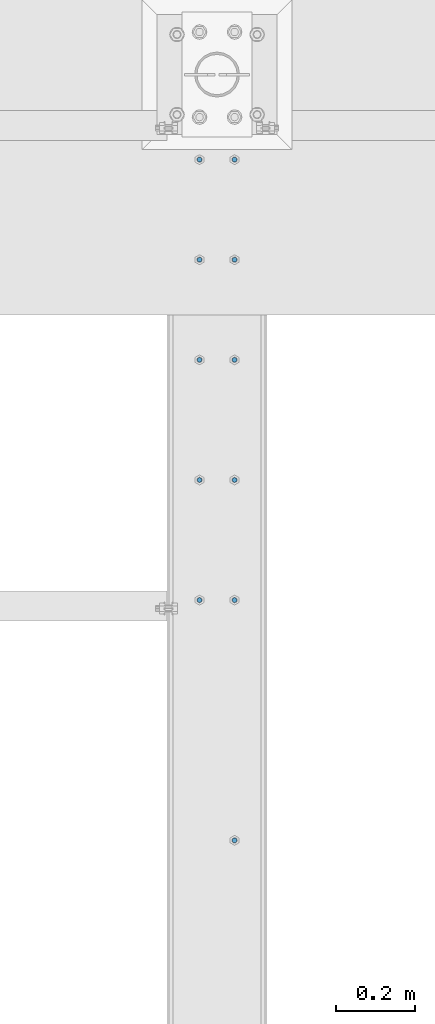
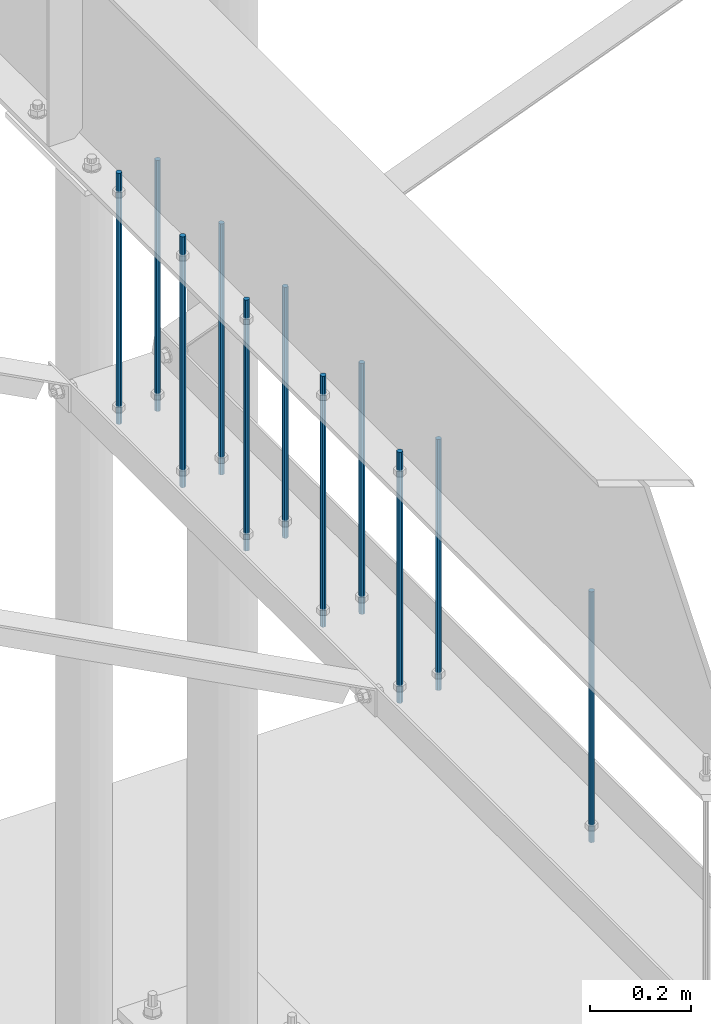
# One storey, part 233 of 975: 11 columns.
"""IFC2X3 building model written with IfcOpenShell, lengths in millimetres."""

from ifc_helpers import new_model, si_unit, frame, origin_with_axes, place, context, subcontext, project, spatial, faceted_brep, material, type_object, element, save


model = new_model("IFC2X3")

# Units and contexts
model_context = context("Model", 3, precision=1e-05, world=origin_with_axes())
body_context = subcontext(model_context, "Body", "Model", "MODEL_VIEW")
ifc_project = project(units=[si_unit("LENGTHUNIT", "METRE", prefix="MILLI"), si_unit("AREAUNIT", "SQUARE_METRE"), si_unit("VOLUMEUNIT", "CUBIC_METRE"), si_unit("MASSUNIT", "GRAM", prefix="KILO"), si_unit("TIMEUNIT", "SECOND"), si_unit("PLANEANGLEUNIT", "RADIAN"), si_unit("SOLIDANGLEUNIT", "STERADIAN"), si_unit("THERMODYNAMICTEMPERATUREUNIT", "DEGREE_CELSIUS"), si_unit("LUMINOUSINTENSITYUNIT", "LUMEN")], contexts=[model_context])

# Site, building, storey
site_placement = place(None, origin_with_axes())
site = spatial("IfcSite", under=ifc_project, at=site_placement, CompositionType="ELEMENT")
building_placement = place(site_placement, origin_with_axes())
building = spatial("IfcBuilding", under=site, at=building_placement, Name="Undefined", CompositionType="ELEMENT")
storey_placement = place(building_placement, origin_with_axes())
storey = spatial("IfcBuildingStorey", under=building, at=storey_placement, Name="Undefined", CompositionType="ELEMENT", Elevation=0.0)

# Columns
ifc_material = material(Name="STEEL/A36")
column_type = type_object("IfcColumnType", PredefinedType="NOTDEFINED")
for number, where, z_axis, x_axis, name in (
    (1, (8274.05, 27771.725, 2870.2), (-0.999999999999998, 6.90000001668524e-08, 0.0), (0.0, 0.0, 1.0), "ALL-THREAD ROD"),
    (2, (8185.15, 27771.725, 2870.2), (-0.999999999999998, 6.90000001668524e-08, 0.0), (0.0, 0.0, 1.0), "ALL-THREAD ROD"),
    (3, (8185.15, 27517.725, 2870.2), (-0.999999999999998, 6.90000001668524e-08, 0.0), (0.0, 0.0, 1.0), "ALL-THREAD ROD"),
    (4, (8185.15, 27212.925, 2870.2), (-0.999999999999998, 6.90000001668524e-08, 0.0), (0.0, 0.0, 1.0), "ALL-THREAD ROD"),
    (5, (8274.05, 26908.125, 2870.2), (-0.999999999999998, 6.90000001668524e-08, 0.0), (0.0, 0.0, 1.0), "ALL-THREAD ROD"),
    (6, (8274.05, 27212.925, 2870.2), (-0.999999999999998, 6.90000001668524e-08, 0.0), (0.0, 0.0, 1.0), "ALL-THREAD ROD"),
    (7, (8274.05, 28025.725, 2870.2), (-0.999999999999998, 6.90000001668524e-08, 0.0), (0.0, 0.0, 1.0), "ALL-THREAD ROD"),
    (8, (8185.15, 28025.725, 2870.2), (-0.999999999999998, 6.90000001668524e-08, 0.0), (0.0, 0.0, 1.0), "ALL-THREAD ROD"),
    (9, (8274.05, 27517.725, 2870.2), (-0.999999999999998, 6.90000001668524e-08, 0.0), (0.0, 0.0, 1.0), "ALL-THREAD ROD"),
    (10, (8274.05, 26298.525, 2870.2), (-0.999999999999998, 6.90000001668524e-08, 0.0), (0.0, 0.0, 1.0), "ALL-THREAD ROD"),
    (11, (8185.15, 26908.125, 2870.2), (-0.999999999999998, 6.90000001668524e-08, 0.0), (0.0, 0.0, 1.0), "ALL-THREAD ROD"),
):
    element("IfcColumn", number, at=place(storey_placement, frame(where, z_axis=z_axis, x_axis=x_axis)), inside=storey, type_object=column_type, material=ifc_material, Name=name, context=body_context, shape_type="Brep", body=[
        faceted_brep([(0.0, -6.34999999998763, -3.63797880709171e-12), (0.0, -4.49012806052269, -4.49012806054634), (609.6, -4.49012806053361, -4.49012806053543), (609.6, -6.34999999999854, 0.0), (0.0, 7.27595761418343e-12, -6.35000000000764), (609.6, 0.0, -6.35000000000036), (0.0, 4.49012806053724, -4.49012806053906), (609.6, 4.49012806053361, -4.49012806053543), (0.0, 6.34999999999491, 5.45696821063757e-12), (609.6, 6.34999999999854, 0.0), (0.0, 4.49012806052633, 4.49012806054634), (609.6, 4.49012806053361, 4.49012806053543), (0.0, 0.0, 6.35000000000764), (609.6, 0.0, 6.35000000000036), (0.0, -4.49012806053361, 4.49012806053543), (609.6, -4.49012806053361, 4.49012806053543)], [[[0, 1, 2, 3]], [[1, 4, 5, 2]], [[4, 6, 7, 5]], [[6, 8, 9, 7]], [[8, 10, 11, 9]], [[10, 12, 13, 11]], [[12, 14, 15, 13]], [[14, 0, 3, 15]], [[5, 7, 9, 11, 13, 15, 3, 2]], [[14, 12, 10, 8, 6, 4, 1, 0]]]),
    ])

save(model, "model.ifc")
